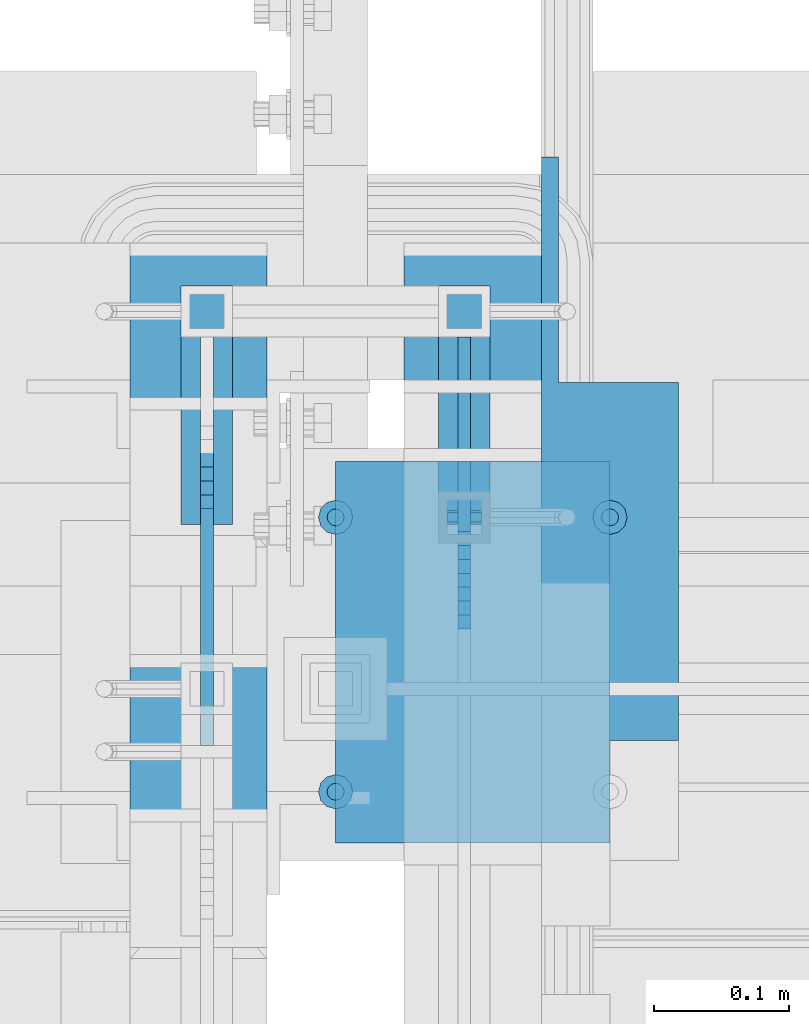
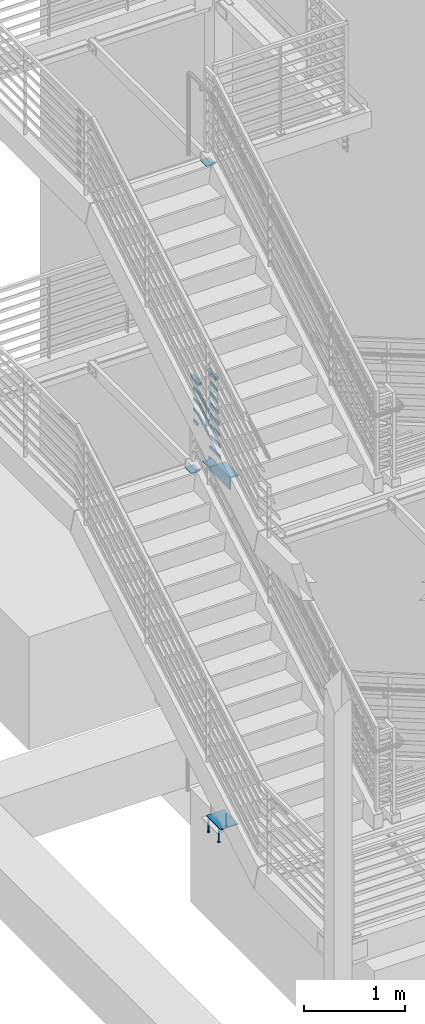
# One storey, part 865 of 1179: 22 beams, 4 members, 10 elements without a shape of their own.
"""IFC2X3 building model written with IfcOpenShell, lengths in millimetres."""

import ifcopenshell
import ifcopenshell.guid

model = None  # the IFC model being written
_history = None  # IfcOwnerHistory: only IFC2X3 demands one
_inside = {}  # id of a spatial element -> (the spatial element, [elements in it])
_under = {}  # id of a project, library or spatial element -> (it, [spatial elements below it])
_declared = {}  # id of a project -> (the project, [libraries it declares])
_typed = {}  # id of a type object -> (the type object, [elements of that type])
_made_of = {}  # id of a material, layer set ... -> (it, [elements and type objects made of it])


def new_model(schema):
    """Start an empty IFC model of exactly this schema.

    Asked for "IFC4X3", IfcOpenShell would pick the latest addendum, in which some entities
    have other attributes; the version numbers below select the first issue.
    IFC2X3 requires an IfcOwnerHistory on every rooted entity: one is made here for all.
    """
    global model, _history
    if schema == "IFC4X3":
        model = ifcopenshell.file(schema_version=(4, 3, 0, 0))
    else:
        model = ifcopenshell.file(schema=schema)
    _inside.clear()
    _under.clear()
    _declared.clear()
    _typed.clear()
    _made_of.clear()
    _history = None
    if model.schema == "IFC2X3":
        org = make("IfcOrganization", Name="unknown")
        user = make(
            "IfcPersonAndOrganization",
            ThePerson=make("IfcPerson", FamilyName="unknown"),
            TheOrganization=org,
        )
        app = make(
            "IfcApplication",
            ApplicationDeveloper=org,
            Version="unknown",
            ApplicationFullName="unknown",
            ApplicationIdentifier="unknown",
        )
        _history = make(
            "IfcOwnerHistory",
            OwningUser=user,
            OwningApplication=app,
            ChangeAction="ADDED",
            CreationDate=0,
        )
    return model


def make(cls, **values):
    """One entity of the class cls with the attributes given. An attribute that is None is left unset."""
    return model.create_entity(
        cls, **{name: value for name, value in values.items() if value is not None}
    )


def rooted(cls, **values):
    """An entity with a GlobalId (a new one), such as an element, a storey or a relation."""
    return make(cls, GlobalId=ifcopenshell.guid.new(), OwnerHistory=_history, **values)


def si_unit(unit_type, name, prefix=None):
    """IfcSIUnit, for example si_unit("LENGTHUNIT", "METRE", prefix="MILLI")."""
    return make("IfcSIUnit", UnitType=unit_type, Prefix=prefix, Name=name)


def assignment(units):
    """IfcUnitAssignment: the units of a project."""
    return None if units is None else make("IfcUnitAssignment", Units=units)


def point(xyz):
    """IfcCartesianPoint."""
    return None if xyz is None else make("IfcCartesianPoint", Coordinates=xyz)


def direction(xyz):
    """IfcDirection."""
    return None if xyz is None else make("IfcDirection", DirectionRatios=xyz)


def frame(location, z_axis=None, x_axis=None):
    """IfcAxis2Placement3D, a coordinate frame: its origin and axes. An axis left out is left unset."""
    return make(
        "IfcAxis2Placement3D",
        Location=point(location),
        Axis=direction(z_axis),
        RefDirection=direction(x_axis),
    )


def origin_with_axes():
    """The frame at (0, 0, 0) with the z axis (0, 0, 1) and the x axis (1, 0, 0) written out."""
    return frame((0.0, 0.0, 0.0), z_axis=(0.0, 0.0, 1.0), x_axis=(1.0, 0.0, 0.0))


def place(relative_to, where):
    """IfcLocalPlacement: puts the frame where relative to a parent placement (None: the world)."""
    return make(
        "IfcLocalPlacement", PlacementRelTo=relative_to, RelativePlacement=where
    )


def context(
    kind, dimensions, precision=None, world=None, true_north=None, identifier=None
):
    """IfcGeometricRepresentationContext, for example the 3D "Model" context."""
    return make(
        "IfcGeometricRepresentationContext",
        ContextIdentifier=identifier,
        ContextType=kind,
        CoordinateSpaceDimension=dimensions,
        Precision=precision,
        WorldCoordinateSystem=world,
        TrueNorth=true_north,
    )


def subcontext(parent, identifier, kind, view, scale=None):
    """IfcGeometricRepresentationSubContext, for example "Body" below "Model"."""
    return make(
        "IfcGeometricRepresentationSubContext",
        ContextIdentifier=identifier,
        ContextType=kind,
        ParentContext=parent,
        TargetScale=scale,
        TargetView=view,
    )


def project(units=None, contexts=None):
    """IfcProject with its units and contexts."""
    return rooted(
        "IfcProject",
        Name="project",
        RepresentationContexts=contexts,
        UnitsInContext=assignment(units),
    )


def spatial(cls, under=None, at=None, **own):
    """A site, building, storey or space (cls), placed at a placement, below another one or the project."""
    s = rooted(cls, ObjectPlacement=at, **own)
    if under is not None:
        _under.setdefault(under.id(), (under, []))[1].append(s)
    return s


def faces_of(points, faces, orient=None, outer=None):
    """IfcFace entities. A face is a list of loops; a loop is a list of indices into points, from 0.

    orient and outer hold one flag for each loop. By default every Orientation is true, the
    first loop of a face is its IfcFaceOuterBound and the others are IfcFaceBound.
    """
    made = []
    for i, loops in enumerate(faces):
        bounds = []
        for j, loop in enumerate(loops):
            is_outer = j == 0 if outer is None else outer[i][j]
            bounds.append(
                make(
                    "IfcFaceOuterBound" if is_outer else "IfcFaceBound",
                    Bound=make("IfcPolyLoop", Polygon=[points[k] for k in loop]),
                    Orientation=True if orient is None else orient[i][j],
                )
            )
        made.append(make("IfcFace", Bounds=bounds))
    return made


def faceted_brep(points, faces, orient=None, outer=None, voids=None):
    """IfcFacetedBrep: a solid bounded by flat faces; with voids (closed shells), ...WithVoids."""
    shared = [point(p) for p in points]
    hull = make("IfcClosedShell", CfsFaces=faces_of(shared, faces, orient, outer))
    if voids is None:
        return make("IfcFacetedBrep", Outer=hull)
    return make(
        "IfcFacetedBrepWithVoids",
        Outer=hull,
        Voids=[
            make(cls, CfsFaces=faces_of(shared, fs, o, b)) for cls, fs, o, b in voids
        ],
    )


def shape(context_of_items, identifier, shape_type, items):
    """IfcShapeRepresentation: the items that make up one representation, for example the "Body"."""
    return make(
        "IfcShapeRepresentation",
        ContextOfItems=context_of_items,
        RepresentationIdentifier=identifier,
        RepresentationType=shape_type,
        Items=items,
    )


def material(Name=None, Category=None):
    """IfcMaterial."""
    return make("IfcMaterial", Name=Name, Category=Category)


def made_of(thing, what):
    """Note that an element or type object is made of a material, layer set ...; save() writes the relation."""
    if what is not None:
        _made_of.setdefault(what.id(), (what, []))[1].append(thing)
    return thing


def type_object(cls, material=None, **own):
    """A type object (cls), such as IfcWallType, which elements share."""
    return made_of(rooted(cls, **own), material)


def element(
    cls,
    number,
    at=None,
    inside=None,
    cuts=None,
    type_object=None,
    material=None,
    context=None,
    identifier="Body",
    shape_type=None,
    held_by="IfcProductDefinitionShape",
    body=None,
    shapes=None,
    **own,
):
    """One element of the class cls, such as IfcWall. Its Tag is "e" and its number.

    at: its placement. inside: the storey or other place that contains it. cuts: it is an
    opening in that element (IfcRelVoidsElement). A single representation is given by context,
    identifier, shape_type and body (its items); several are given by shapes. held_by: the class
    of the entity that holds the representations. save() writes the other relations.
    """
    e = rooted(cls, Tag="e%d" % number, ObjectPlacement=at, **own)
    if body is not None:
        shapes = [shape(context, identifier, shape_type, body)]
    if shapes is not None:
        e.Representation = make(held_by, Representations=shapes)
    if inside is not None:
        _inside.setdefault(inside.id(), (inside, []))[1].append(e)
    if cuts is not None:
        rooted(
            "IfcRelVoidsElement", RelatingBuildingElement=cuts, RelatedOpeningElement=e
        )
    if type_object is not None:
        _typed.setdefault(type_object.id(), (type_object, []))[1].append(e)
    return made_of(e, material)


def aggregate(whole, parts):
    """IfcRelAggregates: a whole, such as a stair, and the parts it consists of."""
    return rooted("IfcRelAggregates", RelatingObject=whole, RelatedObjects=parts)


def save(model, path):
    """Write the relations noted so far, then the file.

    IfcRelAggregates (storeys below a building ...), IfcRelContainedInSpatialStructure (elements
    in a storey), IfcRelDefinesByType, IfcRelAssociatesMaterial and IfcRelDeclares: one each for
    every whole, place, type object, material and project.
    """
    for whole, parts in _under.values():
        aggregate(whole, parts)
    for where, things in _inside.values():
        rooted(
            "IfcRelContainedInSpatialStructure",
            RelatedElements=things,
            RelatingStructure=where,
        )
    for kind, things in _typed.values():
        rooted("IfcRelDefinesByType", RelatedObjects=things, RelatingType=kind)
    for what, things in _made_of.values():
        rooted("IfcRelAssociatesMaterial", RelatedObjects=things, RelatingMaterial=what)
    for by, libraries in _declared.values():
        rooted("IfcRelDeclares", RelatingContext=by, RelatedDefinitions=libraries)
    model.write(path)


model = new_model("IFC2X3")

# Units and contexts
model_context = context("Model", 3, precision=1e-05, world=origin_with_axes())
body_context = subcontext(model_context, "Body", "Model", "MODEL_VIEW")
ifc_project = project(units=[si_unit("LENGTHUNIT", "METRE", prefix="MILLI"), si_unit("AREAUNIT", "SQUARE_METRE"), si_unit("VOLUMEUNIT", "CUBIC_METRE"), si_unit("MASSUNIT", "GRAM", prefix="KILO"), si_unit("TIMEUNIT", "SECOND"), si_unit("PLANEANGLEUNIT", "RADIAN"), si_unit("SOLIDANGLEUNIT", "STERADIAN"), si_unit("THERMODYNAMICTEMPERATUREUNIT", "DEGREE_CELSIUS"), si_unit("LUMINOUSINTENSITYUNIT", "LUMEN")], contexts=[model_context])

# Site, building, storey
site_placement = place(None, origin_with_axes())
site = spatial("IfcSite", under=ifc_project, at=site_placement, CompositionType="ELEMENT")
building_placement = place(site_placement, origin_with_axes())
building = spatial("IfcBuilding", under=site, at=building_placement, Name="Undefined", CompositionType="ELEMENT")
storey_placement = place(building_placement, origin_with_axes())
storey = spatial("IfcBuildingStorey", under=building, at=storey_placement, Name="Undefined", CompositionType="ELEMENT", Elevation=0.0)

# Assembly, beams
assembly_1_placement = place(storey_placement, origin_with_axes())
assembly_1 = element("IfcElementAssembly", 1, at=assembly_1_placement, inside=storey, Name="EMBED", AssemblyPlace="NOTDEFINED", PredefinedType="RIGID_FRAME")
ifc_material_1 = material(Name="STEEL/A108")
beam_type_1 = type_object("IfcBeamType", Name="STUD_1/2-DIA", PredefinedType="NOTDEFINED")
beam_1_placement = place(assembly_1_placement, frame((-1752.60000000632, 35242.4999999998, -12.6999996742202), z_axis=(0.0, 1.0, 0.0), x_axis=(0.0, 0.0, -1.0)))
beam_1 = element("IfcBeam", 2, at=beam_1_placement, type_object=beam_type_1, material=ifc_material_1, Name="STUD", ObjectType="STUD_1/2-DIA", context=body_context, shape_type="Brep", body=[
    faceted_brep([(0.0, -3.1800000667572, 5.5), (0.0, -5.5, 3.1800000667572), (141.732, -5.5, 3.1800000667572), (141.732, -3.1800000667572, 5.5), (0.0, -6.34999999999854, 0.0), (141.732, -6.34999990463257, 0.0), (0.0, -5.5, -3.1800000667572), (141.732, -5.5, -3.1800000667572), (0.0, -3.1800000667572, -5.5), (141.732, -3.1800000667572, -5.5), (0.0, 0.0, -6.34999999999991), (141.732, 0.0, -6.34999990463257), (0.0, 3.1800000667572, -5.5), (141.732, 3.1800000667572, -5.5), (0.0, 5.5, -3.1800000667572), (141.732, 5.5, -3.1800000667572), (0.0, 6.34999999999854, 0.0), (141.732, 6.34999990463257, 0.0), (0.0, 5.5, 3.1800000667572), (141.732, 5.5, 3.1800000667572), (0.0, 3.1800000667572, 5.5), (141.732, 3.1800000667572, 5.5), (0.0, 0.0, 6.34999999999991), (141.732, 0.0, 6.34999990463257), (144.78, -10.9899997711182, 6.34999990463257), (144.78, -6.34000015258789, 10.9899997711182), (144.78, -12.6999998092651, 0.0), (144.78, -10.9899997711182, -6.34999990463257), (144.78, -6.34000015258789, -10.9899997711182), (144.78, 0.0, -12.6899995803833), (144.78, 6.34000015258789, -10.9899997711182), (144.78, 10.9899997711182, -6.34999990463257), (144.78, 12.6999998092651, 0.0), (144.78, 10.9899997711182, 6.34999990463257), (144.78, 6.34000015258789, 10.9899997711182), (144.78, 0.0, 12.6899995803833), (152.4, -10.9899997711182, 6.34999990463257), (152.4, -6.34000015258789, 10.9899997711182), (152.4, -12.6999998092651, 0.0), (152.4, -10.9899997711182, -6.34999990463257), (152.4, -6.34000015258789, -10.9899997711182), (152.4, 0.0, -12.6899995803833), (152.4, 6.34000015258789, -10.9899997711182), (152.4, 10.9899997711182, -6.34999990463257), (152.4, 12.6999998092651, 0.0), (152.4, 10.9899997711182, 6.34999990463257), (152.4, 6.34000015258789, 10.9899997711182), (152.4, 0.0, 12.6899995803833)], [[[0, 1, 2, 3]], [[1, 4, 5, 2]], [[4, 6, 7, 5]], [[6, 8, 9, 7]], [[8, 10, 11, 9]], [[10, 12, 13, 11]], [[12, 14, 15, 13]], [[14, 16, 17, 15]], [[16, 18, 19, 17]], [[18, 20, 21, 19]], [[20, 22, 23, 21]], [[22, 0, 3, 23]], [[22, 20, 18, 16, 14, 12, 10, 8, 6, 4, 1, 0]], [[3, 2, 24, 25]], [[2, 5, 26, 24]], [[5, 7, 27, 26]], [[7, 9, 28, 27]], [[9, 11, 29, 28]], [[11, 13, 30, 29]], [[13, 15, 31, 30]], [[15, 17, 32, 31]], [[17, 19, 33, 32]], [[19, 21, 34, 33]], [[21, 23, 35, 34]], [[23, 3, 25, 35]], [[25, 24, 36, 37]], [[24, 26, 38, 36]], [[26, 27, 39, 38]], [[27, 28, 40, 39]], [[28, 29, 41, 40]], [[29, 30, 42, 41]], [[30, 31, 43, 42]], [[31, 32, 44, 43]], [[32, 33, 45, 44]], [[33, 34, 46, 45]], [[34, 35, 47, 46]], [[35, 25, 37, 47]], [[38, 39, 40, 41, 42, 43, 44, 45, 46, 47, 37, 36]]]),
])
beam_2_placement = place(assembly_1_placement, frame((-1752.60000000632, 35039.2999999998, -12.6999996742202), z_axis=(0.0, 1.0, 0.0), x_axis=(0.0, 0.0, -1.0)))
beam_2 = element("IfcBeam", 3, at=beam_2_placement, type_object=beam_type_1, material=ifc_material_1, Name="STUD", ObjectType="STUD_1/2-DIA", context=body_context, shape_type="Brep", body=[
    faceted_brep([(0.0, -3.1800000667572, 5.5), (0.0, -5.5, 3.1800000667572), (141.732, -5.5, 3.1800000667572), (141.732, -3.1800000667572, 5.5), (0.0, -6.34999999999854, 0.0), (141.732, -6.34999990463257, 0.0), (0.0, -5.5, -3.1800000667572), (141.732, -5.5, -3.1800000667572), (0.0, -3.1800000667572, -5.5), (141.732, -3.1800000667572, -5.5), (0.0, 0.0, -6.34999999999991), (141.732, 0.0, -6.34999990463257), (0.0, 3.1800000667572, -5.5), (141.732, 3.1800000667572, -5.5), (0.0, 5.5, -3.1800000667572), (141.732, 5.5, -3.1800000667572), (0.0, 6.34999999999854, 0.0), (141.732, 6.34999990463257, 0.0), (0.0, 5.5, 3.1800000667572), (141.732, 5.5, 3.1800000667572), (0.0, 3.1800000667572, 5.5), (141.732, 3.1800000667572, 5.5), (0.0, 0.0, 6.34999999999991), (141.732, 0.0, 6.34999990463257), (144.78, -10.9899997711182, 6.34999990463257), (144.78, -6.34000015258789, 10.9899997711182), (144.78, -12.6999998092651, 0.0), (144.78, -10.9899997711182, -6.34999990463257), (144.78, -6.34000015258789, -10.9899997711182), (144.78, 0.0, -12.6899995803833), (144.78, 6.34000015258789, -10.9899997711182), (144.78, 10.9899997711182, -6.34999990463257), (144.78, 12.6999998092651, 0.0), (144.78, 10.9899997711182, 6.34999990463257), (144.78, 6.34000015258789, 10.9899997711182), (144.78, 0.0, 12.6899995803833), (152.4, -10.9899997711182, 6.34999990463257), (152.4, -6.34000015258789, 10.9899997711182), (152.4, -12.6999998092651, 0.0), (152.4, -10.9899997711182, -6.34999990463257), (152.4, -6.34000015258789, -10.9899997711182), (152.4, 0.0, -12.6899995803833), (152.4, 6.34000015258789, -10.9899997711182), (152.4, 10.9899997711182, -6.34999990463257), (152.4, 12.6999998092651, 0.0), (152.4, 10.9899997711182, 6.34999990463257), (152.4, 6.34000015258789, 10.9899997711182), (152.4, 0.0, 12.6899995803833)], [[[0, 1, 2, 3]], [[1, 4, 5, 2]], [[4, 6, 7, 5]], [[6, 8, 9, 7]], [[8, 10, 11, 9]], [[10, 12, 13, 11]], [[12, 14, 15, 13]], [[14, 16, 17, 15]], [[16, 18, 19, 17]], [[18, 20, 21, 19]], [[20, 22, 23, 21]], [[22, 0, 3, 23]], [[22, 20, 18, 16, 14, 12, 10, 8, 6, 4, 1, 0]], [[3, 2, 24, 25]], [[2, 5, 26, 24]], [[5, 7, 27, 26]], [[7, 9, 28, 27]], [[9, 11, 29, 28]], [[11, 13, 30, 29]], [[13, 15, 31, 30]], [[15, 17, 32, 31]], [[17, 19, 33, 32]], [[19, 21, 34, 33]], [[21, 23, 35, 34]], [[23, 3, 25, 35]], [[25, 24, 36, 37]], [[24, 26, 38, 36]], [[26, 27, 39, 38]], [[27, 28, 40, 39]], [[28, 29, 41, 40]], [[29, 30, 42, 41]], [[30, 31, 43, 42]], [[31, 32, 44, 43]], [[32, 33, 45, 44]], [[33, 34, 46, 45]], [[34, 35, 47, 46]], [[35, 25, 37, 47]], [[38, 39, 40, 41, 42, 43, 44, 45, 46, 47, 37, 36]]]),
])
beam_3_placement = place(assembly_1_placement, frame((-1549.40000000632, 35242.5000000001, -12.6999996742202), z_axis=(0.0, 1.0, 0.0), x_axis=(0.0, 0.0, -1.0)))
beam_3 = element("IfcBeam", 4, at=beam_3_placement, type_object=beam_type_1, material=ifc_material_1, Name="STUD", ObjectType="STUD_1/2-DIA", context=body_context, shape_type="Brep", body=[
    faceted_brep([(0.0, -3.1800000667572, 5.5), (0.0, -5.5, 3.1800000667572), (141.732, -5.5, 3.1800000667572), (141.732, -3.1800000667572, 5.5), (0.0, -6.34999999999854, 0.0), (141.732, -6.34999990463257, 0.0), (0.0, -5.5, -3.1800000667572), (141.732, -5.5, -3.1800000667572), (0.0, -3.1800000667572, -5.5), (141.732, -3.1800000667572, -5.5), (0.0, 0.0, -6.34999999999991), (141.732, 0.0, -6.34999990463257), (0.0, 3.1800000667572, -5.5), (141.732, 3.1800000667572, -5.5), (0.0, 5.5, -3.1800000667572), (141.732, 5.5, -3.1800000667572), (0.0, 6.34999999999854, 0.0), (141.732, 6.34999990463257, 0.0), (0.0, 5.5, 3.1800000667572), (141.732, 5.5, 3.1800000667572), (0.0, 3.1800000667572, 5.5), (141.732, 3.1800000667572, 5.5), (0.0, 0.0, 6.34999999999991), (141.732, 0.0, 6.34999990463257), (144.78, -10.9899997711182, 6.34999990463257), (144.78, -6.34000015258789, 10.9899997711182), (144.78, -12.6999998092651, 0.0), (144.78, -10.9899997711182, -6.34999990463257), (144.78, -6.34000015258789, -10.9899997711182), (144.78, 0.0, -12.6899995803833), (144.78, 6.34000015258789, -10.9899997711182), (144.78, 10.9899997711182, -6.34999990463257), (144.78, 12.6999998092651, 0.0), (144.78, 10.9899997711182, 6.34999990463257), (144.78, 6.34000015258789, 10.9899997711182), (144.78, 0.0, 12.6899995803833), (152.4, -10.9899997711182, 6.34999990463257), (152.4, -6.34000015258789, 10.9899997711182), (152.4, -12.6999998092651, 0.0), (152.4, -10.9899997711182, -6.34999990463257), (152.4, -6.34000015258789, -10.9899997711182), (152.4, 0.0, -12.6899995803833), (152.4, 6.34000015258789, -10.9899997711182), (152.4, 10.9899997711182, -6.34999990463257), (152.4, 12.6999998092651, 0.0), (152.4, 10.9899997711182, 6.34999990463257), (152.4, 6.34000015258789, 10.9899997711182), (152.4, 0.0, 12.6899995803833)], [[[0, 1, 2, 3]], [[1, 4, 5, 2]], [[4, 6, 7, 5]], [[6, 8, 9, 7]], [[8, 10, 11, 9]], [[10, 12, 13, 11]], [[12, 14, 15, 13]], [[14, 16, 17, 15]], [[16, 18, 19, 17]], [[18, 20, 21, 19]], [[20, 22, 23, 21]], [[22, 0, 3, 23]], [[22, 20, 18, 16, 14, 12, 10, 8, 6, 4, 1, 0]], [[3, 2, 24, 25]], [[2, 5, 26, 24]], [[5, 7, 27, 26]], [[7, 9, 28, 27]], [[9, 11, 29, 28]], [[11, 13, 30, 29]], [[13, 15, 31, 30]], [[15, 17, 32, 31]], [[17, 19, 33, 32]], [[19, 21, 34, 33]], [[21, 23, 35, 34]], [[23, 3, 25, 35]], [[25, 24, 36, 37]], [[24, 26, 38, 36]], [[26, 27, 39, 38]], [[27, 28, 40, 39]], [[28, 29, 41, 40]], [[29, 30, 42, 41]], [[30, 31, 43, 42]], [[31, 32, 44, 43]], [[32, 33, 45, 44]], [[33, 34, 46, 45]], [[34, 35, 47, 46]], [[35, 25, 37, 47]], [[38, 39, 40, 41, 42, 43, 44, 45, 46, 47, 37, 36]]]),
])
aggregate(assembly_1, [beam_1, beam_2, beam_3])

# Assembly, beam
assembly_2_placement = place(storey_placement, origin_with_axes())
assembly_2 = element("IfcElementAssembly", 5, at=assembly_2_placement, inside=storey, Name="STRINGER", AssemblyPlace="NOTDEFINED", PredefinedType="RIGID_FRAME")
ifc_material_2 = material(Name="STEEL/A36")
beam_type_2 = type_object("IfcBeamType", PredefinedType="NOTDEFINED")
beam_4_placement = place(assembly_2_placement, frame((-1854.20000000477, 35140.8999999964, 8097.8374999989), z_axis=(1.0, 0.0, 0.0), x_axis=(0.0, -1.0, 0.0)))
beam_4 = element("IfcBeam", 6, at=beam_4_placement, type_object=beam_type_2, material=ifc_material_2, Name="PLATE", context=body_context, shape_type="Brep", body=[
    faceted_brep([(0.0, 4.76249999999982, -50.7999999999993), (0.0, 4.76249999999982, 50.7999999999993), (123.824999996345, 4.76249999999982, 50.8), (123.824999996345, 4.76249999999982, -50.8), (0.0, -4.76249999999982, 50.7999999999993), (123.824999996345, -4.76249999999982, 50.8), (0.0, -4.76249999999982, -50.7999999999993), (123.824999996345, -4.76249999999982, -50.8)], [[[0, 1, 2, 3]], [[1, 4, 5, 2]], [[4, 6, 7, 5]], [[6, 0, 3, 7]], [[5, 7, 3, 2]], [[6, 4, 1, 0]]]),
])
aggregate(assembly_2, [beam_4])

assembly_3_placement = place(storey_placement, origin_with_axes())
assembly_3 = element("IfcElementAssembly", 7, at=assembly_3_placement, inside=storey, Name="STRINGER", AssemblyPlace="NOTDEFINED", PredefinedType="RIGID_FRAME")
beam_5_placement = place(assembly_3_placement, frame((-1650.9999999729, 35445.6999999991, 4186.23749999912), z_axis=(1.0, 0.0, 0.0), x_axis=(0.0, -1.0, 0.0)))
beam_5 = element("IfcBeam", 8, at=beam_5_placement, type_object=beam_type_2, material=ifc_material_2, Name="PLATE", context=body_context, shape_type="Brep", body=[
    faceted_brep([(0.0, 4.76249999999982, -50.7999999999993), (0.0, 4.76249999999982, 50.7999999999993), (111.125000010961, 4.76249999999982, 50.8), (111.125000010961, 4.76249999999982, -50.8), (0.0, -4.76249999999982, 50.7999999999993), (111.125000010961, -4.76249999999982, 50.8), (0.0, -4.76249999999982, -50.7999999999993), (111.125000010961, -4.76249999999982, -50.8)], [[[0, 1, 2, 3]], [[1, 4, 5, 2]], [[4, 6, 7, 5]], [[6, 0, 3, 7]], [[5, 7, 3, 2]], [[6, 4, 1, 0]]]),
])
aggregate(assembly_3, [beam_5])

assembly_4_placement = place(storey_placement, origin_with_axes())
assembly_4 = element("IfcElementAssembly", 9, at=assembly_4_placement, inside=storey, Name="STRINGER", AssemblyPlace="NOTDEFINED", PredefinedType="RIGID_FRAME")
beam_6_placement = place(assembly_4_placement, frame((-1854.20000000477, 35445.6999999991, 4186.23749999912), z_axis=(1.0, 0.0, 0.0), x_axis=(0.0, -1.0, 0.0)))
beam_6 = element("IfcBeam", 10, at=beam_6_placement, type_object=beam_type_2, material=ifc_material_2, Name="PLATE", context=body_context, shape_type="Brep", body=[
    faceted_brep([(0.0, 4.76249999999982, -50.7999999999993), (0.0, 4.76249999999982, 50.7999999999993), (123.824999996345, 4.76249999999982, 50.8), (123.824999996345, 4.76249999999982, -50.8), (0.0, -4.76249999999982, 50.7999999999993), (123.824999996345, -4.76249999999982, 50.8), (0.0, -4.76249999999982, -50.7999999999993), (123.824999996345, -4.76249999999982, -50.8)], [[[0, 1, 2, 3]], [[1, 4, 5, 2]], [[4, 6, 7, 5]], [[6, 0, 3, 7]], [[5, 7, 3, 2]], [[6, 4, 1, 0]]]),
])
aggregate(assembly_4, [beam_6])

# Assembly, beams
assembly_5_placement = place(storey_placement, origin_with_axes())
assembly_5 = element("IfcElementAssembly", 11, at=assembly_5_placement, inside=storey, Name="GUARDRAIL", AssemblyPlace="NOTDEFINED", PredefinedType="RIGID_FRAME")
beam_type_3 = type_object("IfcBeamType", PredefinedType="NOTDEFINED")
beam_7_placement = place(assembly_5_placement, frame((-1847.85000076555, 35394.8615863095, 4784.76135061189), z_axis=(0.0, 0.0, 1.0), x_axis=(0.0, -1.0, 0.0)))
beam_7 = element("IfcBeam", 12, at=beam_7_placement, type_object=beam_type_3, material=ifc_material_2, Name="PLATE", context=body_context, shape_type="Brep", body=[
    faceted_brep([(19.0115855454642, 4.76250000000005, -19.0500000000002), (19.0115855454642, 4.76250000000005, 19.0500000000002), (115.264511106456, 4.76250000000005, 19.0500000000002), (105.030504165479, 4.76250000000005, -19.0500000000002), (19.0115855454642, -4.76250000000005, 19.0500000000002), (115.264511106456, -4.76250000000005, 19.0500000000002), (19.0115855454642, -4.76250000000005, -19.0500000000002), (105.030504165479, -4.76250000000005, -19.0500000000002)], [[[0, 1, 2, 3]], [[1, 4, 5, 2]], [[4, 6, 7, 5]], [[6, 0, 3, 7]], [[5, 7, 3, 2]], [[6, 4, 1, 0]]]),
])
beam_8_placement = place(assembly_5_placement, frame((-1847.85000076555, 35394.8999999972, 4914.93611822362), z_axis=(0.0, 0.0, 1.0), x_axis=(0.0, -1.0, 0.0)))
beam_8 = element("IfcBeam", 13, at=beam_8_placement, type_object=beam_type_3, material=ifc_material_2, Name="PLATE", context=body_context, shape_type="Brep", body=[
    faceted_brep([(19.0499992371956, 4.76249999999709, -19.0499999999993), (19.0499992371956, 4.76249999999709, 19.0499999999993), (125.537333109409, 4.76250000000005, 19.0500000000002), (115.30332616844, 4.76250000000005, -19.0500000000002), (19.0499992371956, -4.76249999999709, 19.0499999999993), (125.537333109409, -4.76250000000005, 19.0500000000002), (19.0499992371956, -4.76249999999709, -19.0499999999993), (115.30332616844, -4.76250000000005, -19.0500000000002)], [[[0, 1, 2, 3]], [[1, 4, 5, 2]], [[4, 6, 7, 5]], [[6, 0, 3, 7]], [[5, 7, 3, 2]], [[6, 4, 1, 0]]]),
])
beam_9_placement = place(assembly_5_placement, frame((-1847.85000076555, 35394.8999999973, 5045.11111822362), z_axis=(0.0, 0.0, 1.0), x_axis=(0.0, -1.0, 0.0)))
beam_9 = element("IfcBeam", 14, at=beam_9_placement, type_object=beam_type_3, material=ifc_material_2, Name="PLATE", context=body_context, shape_type="Brep", body=[
    faceted_brep([(19.0499992371956, 4.76249999999709, -19.0499999999993), (19.0499992371956, 4.76249999999709, 19.0499999999993), (135.771340073406, 4.76250000000005, 19.0500000000002), (125.53733313243, 4.76250000000005, -19.0500000000002), (19.0499992371956, -4.76249999999709, 19.0499999999993), (135.771340073406, -4.76250000000005, 19.0500000000002), (19.0499992371956, -4.76249999999709, -19.0499999999993), (125.53733313243, -4.76250000000005, -19.0500000000002)], [[[0, 1, 2, 3]], [[1, 4, 5, 2]], [[4, 6, 7, 5]], [[6, 0, 3, 7]], [[5, 7, 3, 2]], [[6, 4, 1, 0]]]),
])
beam_10_placement = place(assembly_5_placement, frame((-1847.85000076555, 35394.8999999991, 5175.28611822362), z_axis=(0.0, 0.0, 1.0), x_axis=(0.0, -1.0, 0.0)))
beam_10 = element("IfcBeam", 15, at=beam_10_placement, type_object=beam_type_3, material=ifc_material_2, Name="PLATE", context=body_context, shape_type="Brep", body=[
    faceted_brep([(19.0499992371956, 4.76249999999709, -19.0499999999993), (19.0499992371956, 4.76249999999709, 19.0499999999993), (146.005347061327, 4.76250000000005, 19.0500000000002), (135.771340120358, 4.76250000000005, -19.0500000000002), (19.0499992371956, -4.76249999999709, 19.0499999999993), (146.005347061327, -4.76250000000005, 19.0500000000002), (19.0499992371956, -4.76249999999709, -19.0499999999993), (135.771340120358, -4.76250000000005, -19.0500000000002)], [[[0, 1, 2, 3]], [[1, 4, 5, 2]], [[4, 6, 7, 5]], [[6, 0, 3, 7]], [[5, 7, 3, 2]], [[6, 4, 1, 0]]]),
])

assembly_6_placement = place(storey_placement, origin_with_axes())
assembly_6 = element("IfcElementAssembly", 16, at=assembly_6_placement, inside=storey, Name="GUARDRAIL", AssemblyPlace="NOTDEFINED", PredefinedType="RIGID_FRAME")
beam_11_placement = place(assembly_6_placement, frame((-1657.3499991948, 35394.8999999988, 4394.19999999744), z_axis=(0.0, 0.0, 1.0), x_axis=(0.0, -1.0, 0.0)))
beam_11 = element("IfcBeam", 17, at=beam_11_placement, type_object=beam_type_3, material=ifc_material_2, Name="PLATE", context=body_context, shape_type="Brep", body=[
    faceted_brep([(19.0499992371956, 4.76249999999709, -19.0499999999993), (19.0499992371956, 4.76249999999709, 19.0499999999993), (224.775331837285, 4.76250000000005, 19.0500000000002), (235.075634158566, 4.76250000000005, -19.0500000000002), (19.0499992371956, -4.76249999999709, 19.0499999999993), (224.775331837285, -4.76250000000005, 19.0500000000002), (19.0499992371956, -4.76249999999709, -19.0499999999993), (235.075634158566, -4.76250000000005, -19.0500000000002)], [[[0, 1, 2, 3]], [[1, 4, 5, 2]], [[4, 6, 7, 5]], [[6, 0, 3, 7]], [[5, 7, 3, 2]], [[6, 4, 1, 0]]]),
])
beam_12_placement = place(assembly_6_placement, frame((-1657.3499991948, 35394.9, 4524.37499999744), z_axis=(0.0, 0.0, 1.0), x_axis=(0.0, -1.0, 0.0)))
beam_12 = element("IfcBeam", 18, at=beam_12_placement, type_object=beam_type_3, material=ifc_material_2, Name="PLATE", context=body_context, shape_type="Brep", body=[
    faceted_brep([(19.0499992371956, 4.76249999999709, -19.0499999999993), (19.0499992371956, 4.76249999999709, 19.0499999999993), (214.475136877867, 4.76250000000005, 19.0500000000002), (224.775439199148, 4.76250000000005, -19.0500000000002), (19.0499992371956, -4.76249999999709, 19.0499999999993), (214.475136877867, -4.76250000000005, 19.0500000000002), (19.0499992371956, -4.76249999999709, -19.0499999999993), (224.775439199148, -4.76250000000005, -19.0500000000002)], [[[0, 1, 2, 3]], [[1, 4, 5, 2]], [[4, 6, 7, 5]], [[6, 0, 3, 7]], [[5, 7, 3, 2]], [[6, 4, 1, 0]]]),
])
beam_13_placement = place(assembly_6_placement, frame((-1657.3499991948, 35394.9000000001, 4654.54999999744), z_axis=(0.0, 0.0, 1.0), x_axis=(0.0, -1.0, 0.0)))
beam_13 = element("IfcBeam", 19, at=beam_13_placement, type_object=beam_type_3, material=ifc_material_2, Name="PLATE", context=body_context, shape_type="Brep", body=[
    faceted_brep([(19.0499992371956, 4.76249999999709, -19.0499999999993), (19.0499992371956, 4.76249999999709, 19.0499999999993), (204.174670119421, 4.76250000000005, 19.0500000000002), (214.474972440701, 4.76250000000005, -19.0500000000002), (19.0499992371956, -4.76249999999709, 19.0499999999993), (204.174670119421, -4.76250000000005, 19.0500000000002), (19.0499992371956, -4.76249999999709, -19.0499999999993), (214.474972440701, -4.76250000000005, -19.0500000000002)], [[[0, 1, 2, 3]], [[1, 4, 5, 2]], [[4, 6, 7, 5]], [[6, 0, 3, 7]], [[5, 7, 3, 2]], [[6, 4, 1, 0]]]),
])
beam_14_placement = place(assembly_6_placement, frame((-1657.3499991948, 35394.8999999991, 4784.72499999744), z_axis=(0.0, 0.0, 1.0), x_axis=(0.0, -1.0, 0.0)))
beam_14 = element("IfcBeam", 20, at=beam_14_placement, type_object=beam_type_3, material=ifc_material_2, Name="PLATE", context=body_context, shape_type="Brep", body=[
    faceted_brep([(19.0499992371956, 4.76249999999709, -19.0499999999993), (19.0499992371956, 4.76249999999709, 19.0499999999993), (193.874791759459, 4.76250000000005, 19.0500000000002), (204.17509408074, 4.76250000000005, -19.0500000000002), (19.0499992371956, -4.76249999999709, 19.0499999999993), (193.874791759459, -4.76250000000005, 19.0500000000002), (19.0499992371956, -4.76249999999709, -19.0499999999993), (204.17509408074, -4.76250000000005, -19.0500000000002)], [[[0, 1, 2, 3]], [[1, 4, 5, 2]], [[4, 6, 7, 5]], [[6, 0, 3, 7]], [[5, 7, 3, 2]], [[6, 4, 1, 0]]]),
])
beam_15_placement = place(assembly_6_placement, frame((-1657.3499991948, 35394.8999999988, 4914.89999999744), z_axis=(0.0, 0.0, 1.0), x_axis=(0.0, -1.0, 0.0)))
beam_15 = element("IfcBeam", 21, at=beam_15_placement, type_object=beam_type_3, material=ifc_material_2, Name="PLATE", context=body_context, shape_type="Brep", body=[
    faceted_brep([(19.0499992371956, 4.76249999999709, -19.0499999999993), (19.0499992371956, 4.76249999999709, 19.0499999999993), (183.574167981002, 4.76250000000005, 19.0500000000002), (193.874470302282, 4.76250000000005, -19.0500000000002), (19.0499992371956, -4.76249999999709, 19.0499999999993), (183.574167981002, -4.76250000000005, 19.0500000000002), (19.0499992371956, -4.76249999999709, -19.0499999999993), (193.874470302282, -4.76250000000005, -19.0500000000002)], [[[0, 1, 2, 3]], [[1, 4, 5, 2]], [[4, 6, 7, 5]], [[6, 0, 3, 7]], [[5, 7, 3, 2]], [[6, 4, 1, 0]]]),
])
beam_16_placement = place(assembly_6_placement, frame((-1657.3499991948, 35394.9000000002, 5045.07499999744), z_axis=(0.0, 0.0, 1.0), x_axis=(0.0, -1.0, 0.0)))
beam_16 = element("IfcBeam", 22, at=beam_16_placement, type_object=beam_type_3, material=ifc_material_2, Name="PLATE", context=body_context, shape_type="Brep", body=[
    faceted_brep([(19.0499992371956, 4.76249999999709, -19.0499999999993), (19.0499992371956, 4.76249999999709, 19.0499999999993), (173.273865553303, 4.76250000000005, 19.0500000000002), (183.574167874591, 4.76250000000005, -19.0500000000002), (19.0499992371956, -4.76249999999709, 19.0499999999993), (173.273865553303, -4.76250000000005, 19.0500000000002), (19.0499992371956, -4.76249999999709, -19.0499999999993), (183.574167874591, -4.76250000000005, -19.0500000000002)], [[[0, 1, 2, 3]], [[1, 4, 5, 2]], [[4, 6, 7, 5]], [[6, 0, 3, 7]], [[5, 7, 3, 2]], [[6, 4, 1, 0]]]),
])
beam_17_placement = place(assembly_6_placement, frame((-1657.3499991948, 35394.8999999991, 5175.24999999744), z_axis=(0.0, 0.0, 1.0), x_axis=(0.0, -1.0, 0.0)))
beam_17 = element("IfcBeam", 23, at=beam_17_placement, type_object=beam_type_3, material=ifc_material_2, Name="PLATE", context=body_context, shape_type="Brep", body=[
    faceted_brep([(19.0499992371956, 4.76249999999709, -19.0499999999993), (19.0499992371956, 4.76249999999709, 19.0499999999993), (162.973563128275, 4.76250000000005, 19.0500000000002), (173.273865449555, 4.76250000000005, -19.0500000000002), (19.0499992371956, -4.76249999999709, 19.0499999999993), (162.973563128275, -4.76250000000005, 19.0500000000002), (19.0499992371956, -4.76249999999709, -19.0499999999993), (173.273865449555, -4.76250000000005, -19.0500000000002)], [[[0, 1, 2, 3]], [[1, 4, 5, 2]], [[4, 6, 7, 5]], [[6, 0, 3, 7]], [[5, 7, 3, 2]], [[6, 4, 1, 0]]]),
])

# Beam
ifc_material_3 = material()
beam_type_4 = type_object("IfcBeamType", Name="HSS1-1/2X1-1/2X1/4", PredefinedType="NOTDEFINED")
beam_18_placement = place(assembly_5_placement, frame((-1847.85000076555, 35394.8999999991, 5302.24999923251), z_axis=(0.0, 0.0, 1.0), x_axis=(0.0, -1.0, 0.0)))
beam_18 = element("IfcBeam", 24, at=beam_18_placement, type_object=beam_type_4, material=ifc_material_3, Name="GUARDRAIL", ObjectType="HSS1-1/2X1-1/2X1/4", context=body_context, shape_type="Brep", body=[
    faceted_brep([(12.6999993300014, 12.6999993299978, -12.6999993299996), (12.6999993300014, -12.6999993299978, -12.6999993299996), (148.985647594156, -12.6999993300001, -12.6999993299996), (148.985647594156, 12.6999993300001, -12.6999993299996), (-12.6999993299983, -12.6999993299978, 12.6999993299996), (155.822127971667, -12.6999993300001, 12.6999993299996), (-12.6999993299983, 12.6999993299978, 12.6999993299996), (155.822127971667, 12.6999993300001, 12.6999993299996), (19.0499999999993, 19.0499992349996, -19.0499992350015), (-19.0499992350015, 19.0499992350015, 19.0499992349996), (157.531248130639, 19.0499992350001, 19.0499992349996), (147.276527435184, 19.0499992350001, -19.0499992349996), (-19.0499992350015, -19.0499992350015, 19.0499992349996), (157.531248130639, -19.0499992350001, 19.0499992349996), (19.0499999999993, -19.0499992349996, -19.0499992350015), (147.276527435184, -19.0499992350001, -19.0499992349996)], [[[0, 1, 2, 3]], [[1, 4, 5, 2]], [[4, 6, 7, 5]], [[6, 0, 3, 7]], [[8, 9, 10, 11]], [[9, 12, 13, 10]], [[12, 14, 15, 13]], [[14, 8, 11, 15]], [[13, 15, 11, 10], [5, 7, 3, 2]], [[14, 12, 9, 8], [6, 4, 1, 0]]]),
])

# Assembly, beam
assembly_7_placement = place(storey_placement, origin_with_axes())
assembly_7 = element("IfcElementAssembly", 25, at=assembly_7_placement, inside=storey, Name="ANGLE", AssemblyPlace="NOTDEFINED", PredefinedType="RIGID_FRAME")
beam_type_5 = type_object("IfcBeamType", Name="L6X4X1/2", PredefinedType="NOTDEFINED")
beam_19_placement = place(assembly_7_placement, frame((-1549.39999972479, 35509.1999999822, 4105.27499999882), z_axis=(0.0, 0.0, -1.0), x_axis=(0.0, -1.0, 0.0)))
beam_19 = element("IfcBeam", 26, at=beam_19_placement, type_object=beam_type_5, material=ifc_material_2, Name="ANGLE", ObjectType="L6X4X1/2", context=body_context, shape_type="Brep", body=[
    faceted_brep([(0.0, 38.0999999999985, -63.5), (0.0, 38.0999999999985, -76.1999999999998), (166.687500017673, 38.0999999989413, -76.1999999999998), (166.687500017673, 38.0999999999983, -63.5), (166.687499928492, -50.8000000010586, -63.5), (166.687499928492, -50.8000000000018, -76.1999999999998), (431.799999999843, -50.8000000000045, -76.1999999999998), (431.799999999843, -50.8000000000045, -63.5), (0.0, 50.8000000000029, -76.1999999999998), (431.800000000163, 50.7999999999956, -76.1999999999998), (0.0, 38.0999999999985, 76.1999999999998), (0.0, 50.8000000000029, 76.1999999999998), (166.687500017673, 38.0999999999983, 76.1999999999998), (431.800000000119, 38.0999999999956, 76.1999999999998), (431.800000000163, 50.7999999999956, 76.1999999999998), (431.800000000119, 38.0999999999956, -63.5)], [[[0, 1, 2, 3]], [[4, 3, 2, 5]], [[6, 7, 4, 5]], [[1, 8, 9, 6, 5, 2]], [[10, 11, 8, 1, 0]], [[11, 10, 12, 13, 14]], [[8, 11, 14, 9]], [[13, 15, 7, 6, 9, 14]], [[12, 10, 0, 3, 15, 13]], [[7, 15, 3, 4]]]),
])
aggregate(assembly_7, [beam_19])

# Member
member_type_1 = type_object("IfcMemberType", PredefinedType="NOTDEFINED")
member_1_placement = place(assembly_5_placement, frame((-1847.85000076555, 35284.2763232849, 4920.6083122448), z_axis=(0.0, -0.501065882891537, 0.865409140812671), x_axis=(0.0, -0.86540914081267, -0.501065882891538)))
member_1 = element("IfcMember", 27, at=member_1_placement, type_object=member_type_1, material=ifc_material_2, Name="PLATE", context=body_context, shape_type="Brep", body=[
    faceted_brep([(16.4372593891967, 4.76250000000005, -19.0500000000156), (6.20325240173406, 4.76250000000005, 19.0499999999756), (232.300741233827, 4.76250000000005, 19.0499999996664), (254.360376656929, 4.76250000000005, -19.0500000003394), (6.20325240173406, -4.76250000000005, 19.0499999999756), (232.300741233827, -4.76250000000005, 19.0499999996664), (16.4372593891967, -4.76250000000005, -19.0500000000156), (254.360376656929, -4.76250000000005, -19.0500000003394)], [[[0, 1, 2, 3]], [[1, 4, 5, 2]], [[4, 6, 7, 5]], [[6, 0, 3, 7]], [[5, 7, 3, 2]], [[6, 4, 1, 0]]]),
])

member_2_placement = place(assembly_5_placement, frame((-1847.85000076555, 35273.3090069406, 5050.3587312058), z_axis=(0.0, -0.501065882891537, 0.865409140812671), x_axis=(0.0, -0.86540914081267, -0.501065882891538)))
member_2 = element("IfcMember", 28, at=member_2_placement, type_object=member_type_1, material=ifc_material_2, Name="PLATE", context=body_context, shape_type="Brep", body=[
    faceted_brep([(15.5899036751653, 4.76250000000005, -19.0500000000102), (5.35589668769535, 4.76250000000005, 19.0499999999774), (219.627757061375, 4.76250000000005, 19.0499999996864), (241.687392484477, 4.76250000000005, -19.0500000003194), (5.35589668769535, -4.76250000000005, 19.0499999999774), (219.627757061375, -4.76250000000005, 19.0499999996864), (15.5899036751653, -4.76250000000005, -19.0500000000102), (241.687392484477, -4.76250000000005, -19.0500000003194)], [[[0, 1, 2, 3]], [[1, 4, 5, 2]], [[4, 6, 7, 5]], [[6, 0, 3, 7]], [[5, 7, 3, 2]], [[6, 4, 1, 0]]]),
])

member_3_placement = place(assembly_5_placement, frame((-1847.85000076555, 35262.3416905801, 5180.10915017031), z_axis=(0.0, -0.501065882891537, 0.865409140812671), x_axis=(0.0, -0.86540914081267, -0.501065882891538)))
member_3 = element("IfcMember", 29, at=member_3_placement, type_object=member_type_1, material=ifc_material_2, Name="PLATE", context=body_context, shape_type="Brep", body=[
    faceted_brep([(14.7425479681478, 4.76250000000005, -19.0500000000102), (4.50854098067794, 4.76250000000005, 19.0499999999774), (206.954772870136, 4.76250000000005, 19.0499999997046), (229.014408293231, 4.76250000000005, -19.0500000003049), (4.50854098067794, -4.76250000000005, 19.0499999999774), (206.954772870136, -4.76250000000005, 19.0499999997046), (14.7425479681478, -4.76250000000005, -19.0500000000102), (229.014408293231, -4.76250000000005, -19.0500000003049)], [[[0, 1, 2, 3]], [[1, 4, 5, 2]], [[4, 6, 7, 5]], [[6, 0, 3, 7]], [[5, 7, 3, 2]], [[6, 4, 1, 0]]]),
])

aggregate(assembly_5, [member_1, member_2, member_3, beam_7, beam_8, beam_9, beam_10, beam_18])

member_type_2 = type_object("IfcMemberType", Name="HSS1-1/2X1-1/2X1/4", PredefinedType="NOTDEFINED")
member_4_placement = place(assembly_6_placement, frame((-1657.34999921452, 35394.8999999991, 5302.24999923244), z_axis=(0.0, 0.0, 1.0), x_axis=(0.0, -1.0, 0.0)))
member_4 = element("IfcMember", 30, at=member_4_placement, type_object=member_type_2, material=ifc_material_3, Name="GUARDRAIL", ObjectType="HSS1-1/2X1-1/2X1/4", context=body_context, shape_type="Brep", body=[
    faceted_brep([(12.6999993300014, 12.6999993299978, -12.6999993299996), (12.6999993300014, -12.6999993299978, -12.6999993299996), (155.833422246891, -12.6999993300001, -12.6999993299996), (155.833422246891, 12.6999993300001, -12.6999993299996), (-12.6999993299983, -12.6999993299978, 12.6999993299996), (148.966495979323, -12.6999993300001, 12.6999993299996), (-12.6999993299983, 12.6999993299978, 12.6999993299996), (148.966495979323, 12.6999993300001, 12.6999993299996), (19.0499999999993, 19.0499992349996, -19.0499992350015), (-19.0499992350015, 19.0499992350015, 19.0499992349996), (147.249764347544, 19.0499992350001, 19.0499992349996), (157.55015387867, 19.0499992350001, -19.0499992349996), (-19.0499992350015, -19.0499992350015, 19.0499992349996), (147.249764347544, -19.0499992350001, 19.0499992349996), (19.0499999999993, -19.0499992349996, -19.0499992350015), (157.55015387867, -19.0499992350001, -19.0499992349996)], [[[0, 1, 2, 3]], [[1, 4, 5, 2]], [[4, 6, 7, 5]], [[6, 0, 3, 7]], [[8, 9, 10, 11]], [[9, 12, 13, 10]], [[12, 14, 15, 13]], [[14, 8, 11, 15]], [[13, 15, 11, 10], [5, 7, 3, 2]], [[14, 12, 9, 8], [6, 4, 1, 0]]]),
])

aggregate(assembly_6, [beam_11, beam_12, beam_13, beam_14, beam_15, beam_16, beam_17, member_4])

# Assembly, beam
assembly_8_placement = place(storey_placement, origin_with_axes())
assembly_8 = element("IfcElementAssembly", 31, at=assembly_8_placement, inside=storey, Name="LAYER", AssemblyPlace="NOTDEFINED", PredefinedType="RIGID_FRAME")
beam_type_6 = type_object("IfcBeamType", PredefinedType="NOTDEFINED")
beam_20_placement = place(assembly_8_placement, frame((-1651.00000000909, 35001.4516386562, 6.60114782488439), z_axis=(-1.0, 0.0, 0.0), x_axis=(0.0, 1.0, 0.0)))
beam_20 = element("IfcBeam", 32, at=beam_20_placement, type_object=beam_type_6, material=ifc_material_2, Name="LAYER", context=body_context, shape_type="Brep", body=[
    faceted_brep([(1.77351466845721e-11, 3.17500000001064, -101.600000000029), (0.0, 3.17500000000018, 101.599999999999), (282.323718516556, 3.175, 101.6), (282.323718516556, 3.175, -101.6), (0.0, -3.17500000000018, 101.599999999999), (282.323718516556, -3.175, 101.6), (1.8644641386345e-11, -3.17499999998927, -101.600000000031), (282.323718516556, -3.175, -101.6)], [[[0, 1, 2, 3]], [[1, 4, 5, 2]], [[4, 6, 7, 5]], [[6, 0, 3, 7]], [[5, 7, 3, 2]], [[6, 4, 1, 0]]]),
])
aggregate(assembly_8, [beam_20])

assembly_9_placement = place(storey_placement, origin_with_axes())
assembly_9 = element("IfcElementAssembly", 33, at=assembly_9_placement, inside=storey, Name="LAYER", AssemblyPlace="NOTDEFINED", PredefinedType="RIGID_FRAME")
beam_type_7 = type_object("IfcBeamType", PredefinedType="NOTDEFINED")
beam_21_placement = place(assembly_9_placement, frame((-1651.00000000909, 35001.4513846269, 11.4300144842109), z_axis=(-1.0, 0.0, 0.0), x_axis=(0.0, 1.0, 0.0)))
beam_21 = element("IfcBeam", 34, at=beam_21_placement, type_object=beam_type_7, material=ifc_material_2, Name="LAYER", context=body_context, shape_type="Brep", body=[
    faceted_brep([(0.0, 1.5875, -101.6), (0.0, 1.5875, 101.6), (282.323718516556, 1.5875, 101.6), (282.323718516556, 1.5875, -101.6), (0.0, -1.5875, 101.6), (282.323718516556, -1.5875, 101.6), (0.0, -1.5875, -101.6), (282.323718516556, -1.5875, -101.6)], [[[0, 1, 2, 3]], [[1, 4, 5, 2]], [[4, 6, 7, 5]], [[6, 0, 3, 7]], [[5, 7, 3, 2]], [[6, 4, 1, 0]]]),
])
aggregate(assembly_9, [beam_21])

assembly_10_placement = place(storey_placement, origin_with_axes())
assembly_10 = element("IfcElementAssembly", 35, at=assembly_10_placement, inside=storey, Name="LAYER", AssemblyPlace="NOTDEFINED", PredefinedType="RIGID_FRAME")
beam_22_placement = place(assembly_10_placement, frame((-1651.00000000909, 35001.4513846269, 1.83883115454776), z_axis=(-1.0, 0.0, 0.0), x_axis=(0.0, 1.0, 0.0)))
beam_22 = element("IfcBeam", 36, at=beam_22_placement, type_object=beam_type_7, material=ifc_material_2, Name="LAYER", context=body_context, shape_type="Brep", body=[
    faceted_brep([(0.0, 1.5875, -101.6), (0.0, 1.5875, 101.6), (282.323718516556, 1.5875, 101.6), (282.323718516556, 1.5875, -101.6), (0.0, -1.5875, 101.6), (282.323718516556, -1.5875, 101.6), (0.0, -1.5875, -101.6), (282.323718516556, -1.5875, -101.6)], [[[0, 1, 2, 3]], [[1, 4, 5, 2]], [[4, 6, 7, 5]], [[6, 0, 3, 7]], [[5, 7, 3, 2]], [[6, 4, 1, 0]]]),
])
aggregate(assembly_10, [beam_22])

save(model, "model.ifc")
